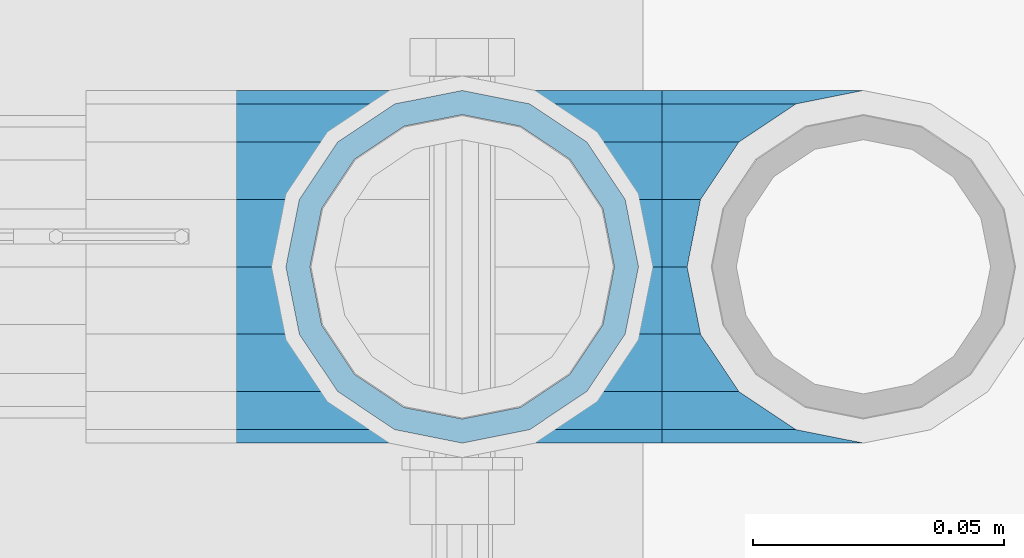
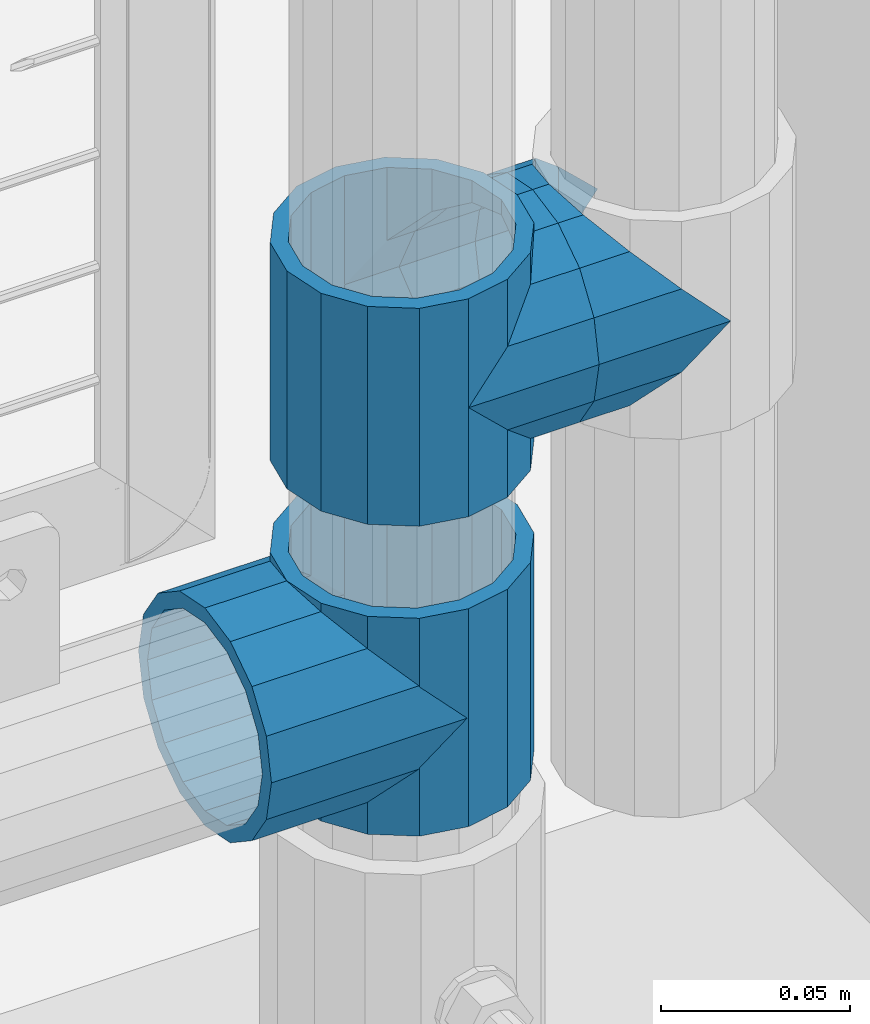
# One storey, part 139 of 208: 5 beams.
"""IFC2X3 building model written with IfcOpenShell, lengths in millimetres."""

import ifcopenshell
import ifcopenshell.guid

model = None  # the IFC model being written
_history = None  # IfcOwnerHistory: only IFC2X3 demands one
_inside = {}  # id of a spatial element -> (the spatial element, [elements in it])
_under = {}  # id of a project, library or spatial element -> (it, [spatial elements below it])
_declared = {}  # id of a project -> (the project, [libraries it declares])
_typed = {}  # id of a type object -> (the type object, [elements of that type])
_made_of = {}  # id of a material, layer set ... -> (it, [elements and type objects made of it])


def new_model(schema):
    """Start an empty IFC model of exactly this schema.

    Asked for "IFC4X3", IfcOpenShell would pick the latest addendum, in which some entities
    have other attributes; the version numbers below select the first issue.
    IFC2X3 requires an IfcOwnerHistory on every rooted entity: one is made here for all.
    """
    global model, _history
    if schema == "IFC4X3":
        model = ifcopenshell.file(schema_version=(4, 3, 0, 0))
    else:
        model = ifcopenshell.file(schema=schema)
    _inside.clear()
    _under.clear()
    _declared.clear()
    _typed.clear()
    _made_of.clear()
    _history = None
    if model.schema == "IFC2X3":
        org = make("IfcOrganization", Name="unknown")
        user = make(
            "IfcPersonAndOrganization",
            ThePerson=make("IfcPerson", FamilyName="unknown"),
            TheOrganization=org,
        )
        app = make(
            "IfcApplication",
            ApplicationDeveloper=org,
            Version="unknown",
            ApplicationFullName="unknown",
            ApplicationIdentifier="unknown",
        )
        _history = make(
            "IfcOwnerHistory",
            OwningUser=user,
            OwningApplication=app,
            ChangeAction="ADDED",
            CreationDate=0,
        )
    return model


def make(cls, **values):
    """One entity of the class cls with the attributes given. An attribute that is None is left unset."""
    return model.create_entity(
        cls, **{name: value for name, value in values.items() if value is not None}
    )


def rooted(cls, **values):
    """An entity with a GlobalId (a new one), such as an element, a storey or a relation."""
    return make(cls, GlobalId=ifcopenshell.guid.new(), OwnerHistory=_history, **values)


def si_unit(unit_type, name, prefix=None):
    """IfcSIUnit, for example si_unit("LENGTHUNIT", "METRE", prefix="MILLI")."""
    return make("IfcSIUnit", UnitType=unit_type, Prefix=prefix, Name=name)


def assignment(units):
    """IfcUnitAssignment: the units of a project."""
    return None if units is None else make("IfcUnitAssignment", Units=units)


def point(xyz):
    """IfcCartesianPoint."""
    return None if xyz is None else make("IfcCartesianPoint", Coordinates=xyz)


def direction(xyz):
    """IfcDirection."""
    return None if xyz is None else make("IfcDirection", DirectionRatios=xyz)


def frame(location, z_axis=None, x_axis=None):
    """IfcAxis2Placement3D, a coordinate frame: its origin and axes. An axis left out is left unset."""
    return make(
        "IfcAxis2Placement3D",
        Location=point(location),
        Axis=direction(z_axis),
        RefDirection=direction(x_axis),
    )


def origin_with_axes():
    """The frame at (0, 0, 0) with the z axis (0, 0, 1) and the x axis (1, 0, 0) written out."""
    return frame((0.0, 0.0, 0.0), z_axis=(0.0, 0.0, 1.0), x_axis=(1.0, 0.0, 0.0))


def place(relative_to, where):
    """IfcLocalPlacement: puts the frame where relative to a parent placement (None: the world)."""
    return make(
        "IfcLocalPlacement", PlacementRelTo=relative_to, RelativePlacement=where
    )


def context(
    kind, dimensions, precision=None, world=None, true_north=None, identifier=None
):
    """IfcGeometricRepresentationContext, for example the 3D "Model" context."""
    return make(
        "IfcGeometricRepresentationContext",
        ContextIdentifier=identifier,
        ContextType=kind,
        CoordinateSpaceDimension=dimensions,
        Precision=precision,
        WorldCoordinateSystem=world,
        TrueNorth=true_north,
    )


def subcontext(parent, identifier, kind, view, scale=None):
    """IfcGeometricRepresentationSubContext, for example "Body" below "Model"."""
    return make(
        "IfcGeometricRepresentationSubContext",
        ContextIdentifier=identifier,
        ContextType=kind,
        ParentContext=parent,
        TargetScale=scale,
        TargetView=view,
    )


def project(units=None, contexts=None):
    """IfcProject with its units and contexts."""
    return rooted(
        "IfcProject",
        Name="project",
        RepresentationContexts=contexts,
        UnitsInContext=assignment(units),
    )


def spatial(cls, under=None, at=None, **own):
    """A site, building, storey or space (cls), placed at a placement, below another one or the project."""
    s = rooted(cls, ObjectPlacement=at, **own)
    if under is not None:
        _under.setdefault(under.id(), (under, []))[1].append(s)
    return s


def faces_of(points, faces, orient=None, outer=None):
    """IfcFace entities. A face is a list of loops; a loop is a list of indices into points, from 0.

    orient and outer hold one flag for each loop. By default every Orientation is true, the
    first loop of a face is its IfcFaceOuterBound and the others are IfcFaceBound.
    """
    made = []
    for i, loops in enumerate(faces):
        bounds = []
        for j, loop in enumerate(loops):
            is_outer = j == 0 if outer is None else outer[i][j]
            bounds.append(
                make(
                    "IfcFaceOuterBound" if is_outer else "IfcFaceBound",
                    Bound=make("IfcPolyLoop", Polygon=[points[k] for k in loop]),
                    Orientation=True if orient is None else orient[i][j],
                )
            )
        made.append(make("IfcFace", Bounds=bounds))
    return made


def faceted_brep(points, faces, orient=None, outer=None, voids=None):
    """IfcFacetedBrep: a solid bounded by flat faces; with voids (closed shells), ...WithVoids."""
    shared = [point(p) for p in points]
    hull = make("IfcClosedShell", CfsFaces=faces_of(shared, faces, orient, outer))
    if voids is None:
        return make("IfcFacetedBrep", Outer=hull)
    return make(
        "IfcFacetedBrepWithVoids",
        Outer=hull,
        Voids=[
            make(cls, CfsFaces=faces_of(shared, fs, o, b)) for cls, fs, o, b in voids
        ],
    )


def shape(context_of_items, identifier, shape_type, items):
    """IfcShapeRepresentation: the items that make up one representation, for example the "Body"."""
    return make(
        "IfcShapeRepresentation",
        ContextOfItems=context_of_items,
        RepresentationIdentifier=identifier,
        RepresentationType=shape_type,
        Items=items,
    )


def material(Name=None, Category=None):
    """IfcMaterial."""
    return make("IfcMaterial", Name=Name, Category=Category)


def made_of(thing, what):
    """Note that an element or type object is made of a material, layer set ...; save() writes the relation."""
    if what is not None:
        _made_of.setdefault(what.id(), (what, []))[1].append(thing)
    return thing


def type_object(cls, material=None, **own):
    """A type object (cls), such as IfcWallType, which elements share."""
    return made_of(rooted(cls, **own), material)


def element(
    cls,
    number,
    at=None,
    inside=None,
    cuts=None,
    type_object=None,
    material=None,
    context=None,
    identifier="Body",
    shape_type=None,
    held_by="IfcProductDefinitionShape",
    body=None,
    shapes=None,
    **own,
):
    """One element of the class cls, such as IfcWall. Its Tag is "e" and its number.

    at: its placement. inside: the storey or other place that contains it. cuts: it is an
    opening in that element (IfcRelVoidsElement). A single representation is given by context,
    identifier, shape_type and body (its items); several are given by shapes. held_by: the class
    of the entity that holds the representations. save() writes the other relations.
    """
    e = rooted(cls, Tag="e%d" % number, ObjectPlacement=at, **own)
    if body is not None:
        shapes = [shape(context, identifier, shape_type, body)]
    if shapes is not None:
        e.Representation = make(held_by, Representations=shapes)
    if inside is not None:
        _inside.setdefault(inside.id(), (inside, []))[1].append(e)
    if cuts is not None:
        rooted(
            "IfcRelVoidsElement", RelatingBuildingElement=cuts, RelatedOpeningElement=e
        )
    if type_object is not None:
        _typed.setdefault(type_object.id(), (type_object, []))[1].append(e)
    return made_of(e, material)


def aggregate(whole, parts):
    """IfcRelAggregates: a whole, such as a stair, and the parts it consists of."""
    return rooted("IfcRelAggregates", RelatingObject=whole, RelatedObjects=parts)


def save(model, path):
    """Write the relations noted so far, then the file.

    IfcRelAggregates (storeys below a building ...), IfcRelContainedInSpatialStructure (elements
    in a storey), IfcRelDefinesByType, IfcRelAssociatesMaterial and IfcRelDeclares: one each for
    every whole, place, type object, material and project.
    """
    for whole, parts in _under.values():
        aggregate(whole, parts)
    for where, things in _inside.values():
        rooted(
            "IfcRelContainedInSpatialStructure",
            RelatedElements=things,
            RelatingStructure=where,
        )
    for kind, things in _typed.values():
        rooted("IfcRelDefinesByType", RelatedObjects=things, RelatingType=kind)
    for what, things in _made_of.values():
        rooted("IfcRelAssociatesMaterial", RelatedObjects=things, RelatingMaterial=what)
    for by, libraries in _declared.values():
        rooted("IfcRelDeclares", RelatingContext=by, RelatedDefinitions=libraries)
    model.write(path)


model = new_model("IFC2X3")

# Units and contexts
model_context = context("Model", 3, precision=1e-05, world=origin_with_axes())
body_context = subcontext(model_context, "Body", "Model", "MODEL_VIEW")
ifc_project = project(units=[si_unit("LENGTHUNIT", "METRE", prefix="MILLI"), si_unit("AREAUNIT", "SQUARE_METRE"), si_unit("VOLUMEUNIT", "CUBIC_METRE"), si_unit("MASSUNIT", "GRAM", prefix="KILO"), si_unit("TIMEUNIT", "SECOND"), si_unit("PLANEANGLEUNIT", "RADIAN"), si_unit("SOLIDANGLEUNIT", "STERADIAN"), si_unit("THERMODYNAMICTEMPERATUREUNIT", "DEGREE_CELSIUS"), si_unit("LUMINOUSINTENSITYUNIT", "LUMEN")], contexts=[model_context])

# Site, building, storey
site_placement = place(None, origin_with_axes())
site = spatial("IfcSite", under=ifc_project, at=site_placement, CompositionType="ELEMENT")
building_placement = place(site_placement, origin_with_axes())
building = spatial("IfcBuilding", under=site, at=building_placement, Name="Standard", CompositionType="ELEMENT")
storey_placement = place(building_placement, origin_with_axes())
storey = spatial("IfcBuildingStorey", under=building, at=storey_placement, Name="Undefined", CompositionType="ELEMENT", Elevation=0.0)

# Beams
ifc_material = material(Name="Misc_Undefined")
beam_type = type_object("IfcBeamType", PredefinedType="NOTDEFINED")
beam_1_placement = place(storey_placement, frame((-26229.0, 4664.5, 298.670000000001), z_axis=(0.0, 1.0, 0.0), x_axis=(-1.0, 0.0, 0.0)))
element("IfcBeam", 1, at=beam_1_placement, inside=storey, type_object=beam_type, material=ifc_material, context=body_context, shape_type="Brep", body=[
    faceted_brep([(13.4513226476338, -13.4513226476329, -32.4743655677721), (13.4513226476338, 13.4513226476329, -32.4743655677721), (0.0, 0.0, -35.1499999999996), (24.8548033587067, -24.8548033587072, 24.8548033587067), (24.8548033587067, -16.3810424080039, 24.8548033587067), (27.1226768591005, -21.4606908090117, 21.4606908090118), (32.4743655677739, -26.8123795176755, 13.4513226476329), (32.4743655677739, -32.4743655677717, 13.4513226476329), (32.8397438117172, -28.0397438117175, 11.6144421722802), (35.1500000000015, -30.35, 0.0), (35.1500000000015, -35.1499999999996, 0.0), (32.8397438117172, -28.0397438117175, -11.6144421722802), (32.4743655677739, -26.8123795176766, -13.4513226476329), (32.4743655677739, -32.4743655677717, -13.4513226476329), (27.1226768591077, -21.4606908090117, -21.4606908090118), (24.8548033587067, -16.3810424080039, -24.8548033587067), (24.8548033587067, -24.8548033587072, -24.8548033587067), (20.0882031229849, -11.6144421722805, -28.0397438117179), (16.6306603983685, 0.0, -30.3500000000004), (20.0882031229849, 11.6144421722805, -28.0397438117179), (24.8548033587067, 16.3810424080023, -24.8548033587067), (24.8548033587067, 24.8548033587072, -24.8548033587067), (32.4743655677739, 26.8123795176755, -13.4513226476329), (32.4743655677739, 32.4743655677717, -13.4513226476329), (27.1226768591077, 21.4606908090117, -21.4606908090118), (35.1500000000015, 30.35, 0.0), (35.1500000000015, 35.15, 0.0), (32.8397438117172, 28.0397438117175, -11.6144421722802), (32.8397438117172, 28.0397438117175, 11.6144421722802), (32.4743655677739, 26.812379517676, 13.4513226476329), (32.4743655677739, 32.4743655677717, 13.4513226476329), (27.1226768591005, 21.4606908090117, 21.4606908090118), (24.8548033587067, 16.3810424080032, 24.8548033587067), (24.8548033587067, 24.8548033587072, 24.8548033587067), (0.0, 0.0, 35.1499999999996), (13.4513226476338, 13.4513226476329, 32.4743655677721), (13.4513226476338, -13.4513226476329, 32.4743655677721), (20.0882031229921, 11.6144421722805, 28.0397438117179), (16.6306603983685, 0.0, 30.3500000000004), (20.0882031229921, -11.6144421722805, 28.0397438117179), (60.1500000000015, -35.15, 0.0), (60.1500000000015, -32.4743655677717, 13.4513226476329), (60.1500000000015, -24.8548033587072, 24.8548033587067), (60.1500000000015, -13.4513226476329, 32.4743655677721), (60.1500000000015, 0.0, 35.1499999999996), (60.1500000000015, -24.8548033587072, -24.8548033587067), (60.1500000000015, -32.4743655677717, -13.4513226476329), (60.1500000000015, -13.4513226476329, -32.4743655677721), (60.1500000000015, 0.0, -35.1499999999996), (60.1500000000015, 13.4513226476329, -32.4743655677721), (60.1500000000015, 24.8548033587072, -24.8548033587067), (60.1500000000015, 32.4743655677717, -13.4513226476329), (60.1500000000015, 35.15, 0.0), (60.1500000000015, 32.4743655677717, 13.4513226476329), (60.1500000000015, 24.8548033587072, 24.8548033587067), (60.1500000000015, 13.4513226476329, 32.4743655677721), (60.1500000000015, -21.4606908090117, 21.4606908090118), (60.1500000000015, -11.6144421722805, 28.0397438117179), (60.1500000000015, 0.0, 30.3500000000004), (60.1500000000015, 11.6144421722805, 28.0397438117179), (60.1500000000015, 21.4606908090117, 21.4606908090118), (60.1500000000015, 28.0397438117175, 11.6144421722802), (60.1500000000015, 30.35, 0.0), (60.1500000000015, 28.0397438117175, -11.6144421722802), (60.1500000000015, 21.4606908090117, -21.4606908090118), (60.1500000000015, 11.6144421722805, -28.0397438117179), (60.1500000000015, 0.0, -30.3500000000004), (60.1500000000015, -11.6144421722805, -28.0397438117179), (60.1500000000015, -21.4606908090117, -21.4606908090118), (60.1500000000015, -28.0397438117175, -11.6144421722802), (60.1500000000015, -30.35, 0.0), (60.1500000000015, -28.0397438117175, 11.6144421722802)], [[[0, 1, 2]], [[3, 4, 5, 6, 7]], [[7, 6, 8, 9, 10]], [[10, 9, 11, 12, 13]], [[13, 12, 14, 15, 16]], [[16, 15, 17, 18, 19, 20, 21, 1, 0]], [[22, 23, 21, 20, 24]], [[25, 26, 23, 22, 27]], [[28, 29, 30, 26, 25]], [[31, 32, 33, 30, 29]], [[34, 35, 36]], [[36, 35, 33, 32, 37, 38, 39, 4, 3]], [[40, 41, 7, 10]], [[41, 42, 3, 7]], [[42, 43, 36, 3]], [[43, 44, 34, 36]], [[45, 46, 13, 16]], [[47, 45, 16, 0]], [[48, 47, 0, 2]], [[49, 48, 2, 1]], [[50, 49, 1, 21]], [[51, 50, 21, 23]], [[52, 51, 23, 26]], [[53, 52, 26, 30]], [[54, 53, 30, 33]], [[55, 54, 33, 35]], [[44, 55, 35, 34]], [[46, 40, 10, 13]], [[45, 47, 48, 49, 50, 51, 52, 53, 54, 55, 44, 43, 42, 41, 40, 46], [56, 57, 58, 59, 60, 61, 62, 63, 64, 65, 66, 67, 68, 69, 70, 71]], [[59, 58, 38, 37]], [[60, 59, 37, 32, 31]], [[61, 60, 31, 29, 28]], [[62, 61, 28, 25]], [[63, 62, 25, 27]], [[24, 64, 63, 27, 22]], [[19, 65, 64, 24, 20]], [[66, 65, 19, 18]], [[67, 66, 18, 17]], [[68, 67, 17, 15, 14]], [[69, 68, 14, 12, 11]], [[70, 69, 11, 9]], [[71, 70, 9, 8]], [[5, 56, 71, 8, 6]], [[39, 57, 56, 5, 4]], [[58, 57, 39, 38]]]),
])
beam_2_placement = place(storey_placement, frame((-26229.0, 4664.5, 333.820000000001), z_axis=(1.0, 0.0, 0.0), x_axis=(0.0, 0.0, -1.0)))
element("IfcBeam", 2, at=beam_2_placement, inside=storey, type_object=beam_type, material=ifc_material, context=body_context, shape_type="Brep", body=[
    faceted_brep([(56.6106908090114, 21.4606908090118, -27.1226768591077), (56.6106908090114, 21.4606908090118, -21.4606908090136), (46.7644421722801, 28.0397438117179, -11.6144421722784), (46.7644421722801, 28.0397438117179, -20.0882031229921), (51.531042408003, 24.8548033587067, -24.8548033587067), (63.1897438117172, 11.6144421722802, -32.8397438117245), (63.1897438117172, 11.6144421722802, -28.0397438117143), (61.962379517676, 13.4513226476329, -32.4743655677739), (65.4999999999997, 0.0, -35.1500000000015), (65.4999999999997, 0.0, -30.3499999999985), (63.1897438117172, -11.6144421722802, -32.8397438117245), (63.1897438117172, -11.6144421722802, -28.0397438117143), (61.962379517675, -13.4513226476329, -32.4743655677739), (56.6106908090114, -21.4606908090118, -27.1226768591005), (56.6106908090114, -21.4606908090118, -21.4606908090136), (51.531042408003, -24.8548033587067, -24.8548033587067), (46.7644421722801, -28.0397438117179, -20.0882031229921), (46.7644421722801, -28.0397438117179, -11.6144421722784), (35.1499999999996, -30.3500000000004, -16.6306603983685), (35.1500000000015, -30.35, 0.0), (23.5355578277191, -28.0397438117179, -20.0882031229921), (23.5355578277191, -28.0397438117179, -11.6144421722784), (13.6893091909879, -21.4606908090118, -27.1226768591005), (13.6893091909879, -21.4606908090118, -21.4606908090136), (18.7689575919962, -24.8548033587067, -24.8548033587067), (7.11025618828205, -11.6144421722802, -32.8397438117245), (7.11025618828205, -11.6144421722802, -28.0397438117143), (8.33762048232325, -13.4513226476329, -32.4743655677739), (4.79999999999961, 0.0, -35.1500000000015), (4.79999999999961, 0.0, -30.3499999999985), (7.11025618828211, 11.6144421722802, -32.8397438117245), (7.11025618828211, 11.6144421722802, -28.0397438117143), (8.33762048232325, 13.4513226476329, -32.4743655677739), (13.6893091909879, 21.4606908090118, -27.1226768591077), (13.6893091909879, 21.4606908090118, -21.4606908090136), (18.7689575919962, 24.8548033587067, -24.8548033587067), (23.5355578277192, 28.0397438117179, -20.0882031229921), (23.5355578277192, 28.0397438117179, -11.6144421722784), (35.1499999999996, 30.3500000000004, -16.6306603983685), (35.1500000000015, 30.35, 0.0), (0.0, 32.4743655677721, -13.4513226476338), (0.0, 35.1499999999996, 0.0), (70.2999999999993, 35.1499999999996, 0.0), (70.2999999999993, 32.4743655677721, -13.4513226476338), (0.0, 32.4743655677721, 13.4513226476338), (70.2999999999993, 32.4743655677721, 13.4513226476338), (0.0, 24.8548033587067, 24.8548033587067), (70.2999999999993, 24.8548033587067, 24.8548033587067), (0.0, 13.4513226476329, 32.4743655677739), (70.2999999999993, 13.4513226476329, 32.4743655677739), (0.0, 0.0, 35.1499999999996), (70.2999999999993, 0.0, 35.1500000000015), (0.0, -13.4513226476329, 32.4743655677739), (70.2999999999993, -13.4513226476329, 32.4743655677739), (0.0, -24.8548033587067, 24.8548033587067), (70.2999999999993, -24.8548033587067, 24.8548033587067), (0.0, -32.4743655677721, 13.4513226476338), (70.2999999999993, -32.4743655677721, 13.4513226476338), (0.0, -35.1499999999996, 0.0), (70.2999999999993, -35.1499999999996, 0.0), (70.2999999999993, -30.3500000000004, 0.0), (70.2999999999993, -28.0397438117179, -11.6144421722784), (70.2999999999993, -21.4606908090118, -21.4606908090136), (70.2999999999993, -11.6144421722802, -28.0397438117143), (70.2999999999993, 0.0, -30.3499999999985), (70.2999999999993, 11.6144421722802, -28.0397438117143), (70.2999999999993, 21.4606908090118, -21.4606908090136), (70.2999999999993, 28.0397438117179, -11.6144421722784), (0.0, -28.0397438117179, -11.6144421722784), (0.0, -30.3500000000004, 0.0), (0.0, -21.4606908090118, -21.4606908090136), (0.0, -11.6144421722802, -28.0397438117143), (0.0, 0.0, -30.3499999999985), (0.0, 11.6144421722802, -28.0397438117143), (0.0, 21.4606908090118, -21.4606908090136), (0.0, 28.0397438117179, -11.6144421722784), (0.0, 30.3500000000004, 0.0), (70.2999999999993, 30.3500000000004, 0.0), (0.0, 28.0397438117179, 11.6144421722784), (70.2999999999993, 28.0397438117179, 11.6144421722784), (0.0, 21.4606908090118, 21.4606908090136), (70.2999999999993, 21.4606908090118, 21.4606908090136), (0.0, 11.6144421722802, 28.0397438117143), (70.2999999999993, 11.6144421722802, 28.0397438117143), (0.0, 0.0, 30.3499999999985), (70.2999999999993, 0.0, 30.3499999999985), (0.0, -11.6144421722802, 28.0397438117143), (70.2999999999993, -11.6144421722802, 28.0397438117143), (0.0, -21.4606908090118, 21.4606908090136), (70.2999999999993, -21.4606908090118, 21.4606908090136), (0.0, -28.0397438117179, 11.6144421722784), (70.2999999999993, -28.0397438117179, 11.6144421722784), (70.2999999999993, -24.8548033587067, -24.8548033587067), (70.2999999999993, -13.4513226476329, -32.4743655677739), (70.2999999999993, 0.0, -35.1500000000015), (70.2999999999993, 13.4513226476329, -32.4743655677739), (70.2999999999993, 24.8548033587067, -24.8548033587067), (70.2999999999993, -32.4743655677721, -13.4513226476338), (0.0, -32.4743655677721, -13.4513226476338), (0.0, 24.8548033587067, -24.8548033587067), (0.0, 13.4513226476329, -32.4743655677739), (0.0, 0.0, -35.1499999999996), (0.0, -13.4513226476329, -32.4743655677739), (0.0, -24.8548033587067, -24.8548033587067)], [[[0, 1, 2, 3, 4]], [[5, 6, 1, 0, 7]], [[8, 9, 6, 5]], [[10, 11, 9, 8]], [[12, 13, 14, 11, 10]], [[15, 16, 17, 14, 13]], [[18, 19, 17, 16]], [[20, 21, 19, 18]], [[22, 23, 21, 20, 24]], [[25, 26, 23, 22, 27]], [[28, 29, 26, 25]], [[30, 31, 29, 28]], [[32, 33, 34, 31, 30]], [[35, 36, 37, 34, 33]], [[38, 39, 37, 36]], [[3, 2, 39, 38]], [[40, 41, 42, 43]], [[41, 44, 45, 42]], [[44, 46, 47, 45]], [[46, 48, 49, 47]], [[48, 50, 51, 49]], [[50, 52, 53, 51]], [[52, 54, 55, 53]], [[54, 56, 57, 55]], [[56, 58, 59, 57]], [[60, 61, 17, 19]], [[61, 62, 14, 17]], [[62, 63, 11, 14]], [[63, 64, 9, 11]], [[64, 65, 6, 9]], [[65, 66, 1, 6]], [[66, 67, 2, 1]], [[68, 69, 19, 21]], [[70, 68, 21, 23]], [[71, 70, 23, 26]], [[72, 71, 26, 29]], [[73, 72, 29, 31]], [[74, 73, 31, 34]], [[75, 74, 34, 37]], [[76, 75, 37, 39]], [[67, 77, 39, 2]], [[78, 76, 39, 77, 79]], [[80, 78, 79, 81]], [[82, 80, 81, 83]], [[84, 82, 83, 85]], [[86, 84, 85, 87]], [[88, 86, 87, 89]], [[90, 88, 89, 91]], [[19, 69, 90, 91, 60]], [[92, 93, 94, 95, 96, 43, 42, 45, 47, 49, 51, 53, 55, 57, 59, 97], [89, 87, 85, 83, 81, 79, 77, 67, 66, 65, 64, 63, 62, 61, 60, 91]], [[58, 98, 97, 59]], [[56, 54, 52, 50, 48, 46, 44, 41, 40, 99, 100, 101, 102, 103, 98, 58], [68, 70, 71, 72, 73, 74, 75, 76, 78, 80, 82, 84, 86, 88, 90, 69]], [[100, 99, 35, 33, 32]], [[101, 100, 32, 30, 28]], [[27, 102, 101, 28, 25]], [[24, 103, 102, 27, 22]], [[92, 97, 98, 103, 24, 20, 18, 16, 15]], [[93, 92, 15, 13, 12]], [[94, 93, 12, 10, 8]], [[7, 95, 94, 8, 5]], [[4, 96, 95, 7, 0]], [[38, 36, 35, 99, 40, 43, 96, 4, 3]]]),
])
beam_3_placement = place(storey_placement, frame((-26229.0, 4664.5, 398.670000000001), z_axis=(0.0, -1.0, 0.0), x_axis=(1.0, 0.0, 0.0)))
element("IfcBeam", 3, at=beam_3_placement, inside=storey, type_object=beam_type, material=ifc_material, context=body_context, shape_type="Brep", body=[
    faceted_brep([(13.4513226476338, -13.4513226476329, -32.4743655677721), (13.4513226476338, 13.4513226476329, -32.4743655677721), (0.0, 0.0, -35.1499999999996), (27.1226768591005, 21.4606908090117, 21.4606908090118), (24.8548033587067, 16.3810424080032, 24.8548033587067), (24.8548033587067, 24.8548033587072, 24.8548033587067), (32.4743655677739, 32.4743655677717, 13.4513226476329), (32.4743655677739, 26.812379517676, 13.4513226476329), (0.0, 0.0, 35.1499999999996), (13.4513226476338, 13.4513226476329, 32.4743655677721), (13.4513226476338, -13.4513226476329, 32.4743655677721), (20.0882031229921, 11.6144421722805, 28.0397438117179), (16.6306603983685, 0.0, 30.3500000000004), (20.0882031229921, -11.6144421722805, 28.0397438117179), (24.8548033587067, -16.3810424080039, 24.8548033587067), (24.8548033587067, -24.8548033587072, 24.8548033587067), (27.1226768591005, -21.4606908090117, 21.4606908090118), (32.4743655677739, -26.8123795176755, 13.4513226476329), (32.4743655677739, -32.4743655677717, 13.4513226476329), (32.8397438117172, -28.0397438117175, 11.6144421722802), (35.1500000000015, -30.35, 0.0), (35.1500000000015, -35.1499999999996, 0.0), (32.8397438117172, -28.0397438117175, -11.6144421722802), (32.4743655677739, -26.8123795176766, -13.4513226476329), (32.4743655677739, -32.4743655677717, -13.4513226476329), (27.1226768591077, -21.4606908090117, -21.4606908090118), (24.8548033587067, -16.3810424080039, -24.8548033587067), (24.8548033587067, -24.8548033587072, -24.8548033587067), (20.0882031229849, -11.6144421722805, -28.0397438117179), (16.6306603983685, 0.0, -30.3500000000004), (20.0882031229849, 11.6144421722805, -28.0397438117179), (24.8548033587067, 16.3810424080023, -24.8548033587067), (24.8548033587067, 24.8548033587072, -24.8548033587067), (32.4743655677739, 26.8123795176755, -13.4513226476329), (32.4743655677739, 32.4743655677717, -13.4513226476329), (27.1226768591077, 21.4606908090117, -21.4606908090118), (35.1500000000015, 30.35, 0.0), (35.1500000000015, 35.15, 0.0), (32.8397438117172, 28.0397438117175, -11.6144421722802), (32.8397438117172, 28.0397438117175, 11.6144421722802), (40.1500000000015, -35.15, 0.0), (40.1500000000015, -32.4743655677717, 13.4513226476329), (40.1500000000015, -24.8548033587072, 24.8548033587067), (40.1500000000015, -13.4513226476329, 32.4743655677721), (40.1500000000015, 0.0, 35.1499999999996), (40.1500000000015, 13.4513226476329, 32.4743655677721), (40.1500000000015, 24.8548033587072, 24.8548033587067), (40.1500000000015, 32.4743655677717, 13.4513226476329), (40.1500000000015, 35.15, 0.0), (40.1500000000015, -24.8548033587072, -24.8548033587067), (40.1500000000015, -32.4743655677717, -13.4513226476329), (40.1500000000015, -13.4513226476329, -32.4743655677721), (40.1500000000015, 0.0, -35.1499999999996), (40.1500000000015, 13.4513226476329, -32.4743655677721), (40.1500000000015, 24.8548033587072, -24.8548033587067), (40.1500000000015, 32.4743655677717, -13.4513226476329), (40.1500000000015, -21.4606908090117, 21.4606908090118), (40.1500000000015, -11.6144421722805, 28.0397438117179), (40.1500000000015, 0.0, 30.3500000000004), (40.1500000000015, 11.6144421722805, 28.0397438117179), (40.1500000000015, 21.4606908090117, 21.4606908090118), (40.1500000000015, 28.0397438117175, 11.6144421722802), (40.1500000000015, 30.35, 0.0), (40.1500000000015, 28.0397438117175, -11.6144421722802), (40.1500000000015, 21.4606908090117, -21.4606908090118), (40.1500000000015, 11.6144421722805, -28.0397438117179), (40.1500000000015, 0.0, -30.3500000000004), (40.1500000000015, -11.6144421722805, -28.0397438117179), (40.1500000000015, -21.4606908090117, -21.4606908090118), (40.1500000000015, -28.0397438117175, -11.6144421722802), (40.1500000000015, -30.35, 0.0), (40.1500000000015, -28.0397438117175, 11.6144421722802)], [[[0, 1, 2]], [[3, 4, 5, 6, 7]], [[8, 9, 10]], [[10, 9, 5, 4, 11, 12, 13, 14, 15]], [[15, 14, 16, 17, 18]], [[18, 17, 19, 20, 21]], [[21, 20, 22, 23, 24]], [[24, 23, 25, 26, 27]], [[27, 26, 28, 29, 30, 31, 32, 1, 0]], [[33, 34, 32, 31, 35]], [[36, 37, 34, 33, 38]], [[39, 7, 6, 37, 36]], [[40, 41, 18, 21]], [[41, 42, 15, 18]], [[42, 43, 10, 15]], [[43, 44, 8, 10]], [[44, 45, 9, 8]], [[45, 46, 5, 9]], [[46, 47, 6, 5]], [[47, 48, 37, 6]], [[49, 50, 24, 27]], [[51, 49, 27, 0]], [[52, 51, 0, 2]], [[53, 52, 2, 1]], [[54, 53, 1, 32]], [[55, 54, 32, 34]], [[48, 55, 34, 37]], [[50, 40, 21, 24]], [[49, 51, 52, 53, 54, 55, 48, 47, 46, 45, 44, 43, 42, 41, 40, 50], [56, 57, 58, 59, 60, 61, 62, 63, 64, 65, 66, 67, 68, 69, 70, 71]], [[63, 62, 36, 38]], [[35, 64, 63, 38, 33]], [[30, 65, 64, 35, 31]], [[66, 65, 30, 29]], [[67, 66, 29, 28]], [[68, 67, 28, 26, 25]], [[69, 68, 25, 23, 22]], [[70, 69, 22, 20]], [[71, 70, 20, 19]], [[16, 56, 71, 19, 17]], [[13, 57, 56, 16, 14]], [[58, 57, 13, 12]], [[59, 58, 12, 11]], [[60, 59, 11, 4, 3]], [[61, 60, 3, 7, 39]], [[62, 61, 39, 36]]]),
])
beam_4_placement = place(storey_placement, frame((-26149.0, 4664.5, 398.670000000001), z_axis=(0.0, 1.0, 0.0), x_axis=(-1.0, 0.0, 0.0)))
element("IfcBeam", 4, at=beam_4_placement, inside=storey, type_object=beam_type, material=ifc_material, context=body_context, shape_type="Brep", body=[
    faceted_brep([(13.4513226476338, -13.4513226476329, -32.4743655677721), (13.4513226476338, 13.4513226476329, -32.4743655677721), (0.0, 0.0, -35.1499999999996), (24.8548033587067, -24.8548033587072, 24.8548033587067), (24.8548033587067, -16.3810424080039, 24.8548033587067), (27.1226768591005, -21.4606908090117, 21.4606908090118), (32.4743655677739, -26.8123795176755, 13.4513226476329), (32.4743655677739, -32.4743655677717, 13.4513226476329), (32.8397438117172, -28.0397438117175, 11.6144421722802), (35.1500000000015, -30.35, 0.0), (35.1500000000015, -35.1499999999996, 0.0), (32.8397438117172, -28.0397438117175, -11.6144421722802), (32.4743655677739, -26.8123795176766, -13.4513226476329), (32.4743655677739, -32.4743655677717, -13.4513226476329), (27.1226768591077, -21.4606908090117, -21.4606908090118), (24.8548033587067, -16.3810424080039, -24.8548033587067), (24.8548033587067, -24.8548033587072, -24.8548033587067), (20.0882031229849, -11.6144421722805, -28.0397438117179), (16.6306603983685, 0.0, -30.3500000000004), (20.0882031229849, 11.6144421722805, -28.0397438117179), (24.8548033587067, 16.3810424080023, -24.8548033587067), (24.8548033587067, 24.8548033587072, -24.8548033587067), (32.4743655677739, 26.8123795176755, -13.4513226476329), (32.4743655677739, 32.4743655677717, -13.4513226476329), (27.1226768591077, 21.4606908090117, -21.4606908090118), (35.1500000000015, 30.35, 0.0), (35.1500000000015, 35.15, 0.0), (32.8397438117172, 28.0397438117175, -11.6144421722802), (32.8397438117172, 28.0397438117175, 11.6144421722802), (32.4743655677739, 26.812379517676, 13.4513226476329), (32.4743655677739, 32.4743655677717, 13.4513226476329), (27.1226768591005, 21.4606908090117, 21.4606908090118), (24.8548033587067, 16.3810424080032, 24.8548033587067), (24.8548033587067, 24.8548033587072, 24.8548033587067), (0.0, 0.0, 35.1499999999996), (13.4513226476338, 13.4513226476329, 32.4743655677721), (13.4513226476338, -13.4513226476329, 32.4743655677721), (20.0882031229921, 11.6144421722805, 28.0397438117179), (16.6306603983685, 0.0, 30.3500000000004), (20.0882031229921, -11.6144421722805, 28.0397438117179), (40.1500000000015, -35.15, 0.0), (40.1500000000015, -32.4743655677717, 13.4513226476329), (40.1500000000015, -24.8548033587072, 24.8548033587067), (40.1500000000015, -13.4513226476329, 32.4743655677721), (40.1500000000015, 0.0, 35.1499999999996), (40.1500000000015, -24.8548033587072, -24.8548033587067), (40.1500000000015, -32.4743655677717, -13.4513226476329), (40.1500000000015, -13.4513226476329, -32.4743655677721), (40.1500000000015, 0.0, -35.1499999999996), (40.1500000000015, 13.4513226476329, -32.4743655677721), (40.1500000000015, 24.8548033587072, -24.8548033587067), (40.1500000000015, 32.4743655677717, -13.4513226476329), (40.1500000000015, 35.15, 0.0), (40.1500000000015, 32.4743655677717, 13.4513226476329), (40.1500000000015, 24.8548033587072, 24.8548033587067), (40.1500000000015, 13.4513226476329, 32.4743655677721), (40.1500000000015, -21.4606908090117, 21.4606908090118), (40.1500000000015, -11.6144421722805, 28.0397438117179), (40.1500000000015, 0.0, 30.3500000000004), (40.1500000000015, 11.6144421722805, 28.0397438117179), (40.1500000000015, 21.4606908090117, 21.4606908090118), (40.1500000000015, 28.0397438117175, 11.6144421722802), (40.1500000000015, 30.35, 0.0), (40.1500000000015, 28.0397438117175, -11.6144421722802), (40.1500000000015, 21.4606908090117, -21.4606908090118), (40.1500000000015, 11.6144421722805, -28.0397438117179), (40.1500000000015, 0.0, -30.3500000000004), (40.1500000000015, -11.6144421722805, -28.0397438117179), (40.1500000000015, -21.4606908090117, -21.4606908090118), (40.1500000000015, -28.0397438117175, -11.6144421722802), (40.1500000000015, -30.35, 0.0), (40.1500000000015, -28.0397438117175, 11.6144421722802)], [[[0, 1, 2]], [[3, 4, 5, 6, 7]], [[7, 6, 8, 9, 10]], [[10, 9, 11, 12, 13]], [[13, 12, 14, 15, 16]], [[16, 15, 17, 18, 19, 20, 21, 1, 0]], [[22, 23, 21, 20, 24]], [[25, 26, 23, 22, 27]], [[28, 29, 30, 26, 25]], [[31, 32, 33, 30, 29]], [[34, 35, 36]], [[36, 35, 33, 32, 37, 38, 39, 4, 3]], [[40, 41, 7, 10]], [[41, 42, 3, 7]], [[42, 43, 36, 3]], [[43, 44, 34, 36]], [[45, 46, 13, 16]], [[47, 45, 16, 0]], [[48, 47, 0, 2]], [[49, 48, 2, 1]], [[50, 49, 1, 21]], [[51, 50, 21, 23]], [[52, 51, 23, 26]], [[53, 52, 26, 30]], [[54, 53, 30, 33]], [[55, 54, 33, 35]], [[44, 55, 35, 34]], [[46, 40, 10, 13]], [[45, 47, 48, 49, 50, 51, 52, 53, 54, 55, 44, 43, 42, 41, 40, 46], [56, 57, 58, 59, 60, 61, 62, 63, 64, 65, 66, 67, 68, 69, 70, 71]], [[59, 58, 38, 37]], [[60, 59, 37, 32, 31]], [[61, 60, 31, 29, 28]], [[62, 61, 28, 25]], [[63, 62, 25, 27]], [[24, 64, 63, 27, 22]], [[19, 65, 64, 24, 20]], [[66, 65, 19, 18]], [[67, 66, 18, 17]], [[68, 67, 17, 15, 14]], [[69, 68, 14, 12, 11]], [[70, 69, 11, 9]], [[71, 70, 9, 8]], [[5, 56, 71, 8, 6]], [[39, 57, 56, 5, 4]], [[58, 57, 39, 38]]]),
])
beam_5_placement = place(storey_placement, frame((-26229.0, 4664.5, 433.82), z_axis=(-1.0, 0.0, 0.0), x_axis=(0.0, 0.0, -1.0)))
element("IfcBeam", 5, at=beam_5_placement, inside=storey, type_object=beam_type, material=ifc_material, context=body_context, shape_type="Brep", body=[
    faceted_brep([(7.11025618828205, -11.6144421722802, -32.8397438117245), (7.11025618828205, -11.6144421722802, -28.0397438117143), (13.6893091909879, -21.4606908090118, -21.4606908090136), (13.6893091909879, -21.4606908090118, -27.1226768591005), (8.33762048232325, -13.4513226476329, -32.4743655677739), (23.5355578277191, -28.0397438117179, -11.6144421722784), (23.5355578277191, -28.0397438117179, -20.0882031229921), (18.7689575919962, -24.8548033587067, -24.8548033587067), (35.1500000000015, -30.35, 0.0), (35.1499999999996, -30.3500000000004, -16.6306603983685), (46.7644421722801, -28.0397438117179, -11.6144421722784), (46.7644421722801, -28.0397438117179, -20.0882031229921), (51.531042408003, -24.8548033587067, -24.8548033587067), (56.6106908090114, -21.4606908090118, -21.4606908090136), (56.6106908090114, -21.4606908090118, -27.1226768591005), (61.962379517675, -13.4513226476329, -32.4743655677739), (63.1897438117172, -11.6144421722802, -28.0397438117143), (63.1897438117172, -11.6144421722802, -32.8397438117245), (65.4999999999997, 0.0, -30.3499999999985), (65.4999999999997, 0.0, -35.1500000000015), (63.1897438117172, 11.6144421722802, -28.0397438117143), (63.1897438117172, 11.6144421722802, -32.8397438117245), (56.6106908090114, 21.4606908090118, -21.4606908090136), (56.6106908090114, 21.4606908090118, -27.1226768591077), (61.962379517676, 13.4513226476329, -32.4743655677739), (46.7644421722801, 28.0397438117179, -11.6144421722784), (46.7644421722801, 28.0397438117179, -20.0882031229921), (51.531042408003, 24.8548033587067, -24.8548033587067), (35.1500000000015, 30.35, 0.0), (35.1499999999996, 30.3500000000004, -16.6306603983685), (23.5355578277192, 28.0397438117179, -11.6144421722784), (23.5355578277192, 28.0397438117179, -20.0882031229921), (18.7689575919962, 24.8548033587067, -24.8548033587067), (13.6893091909879, 21.4606908090118, -21.4606908090136), (13.6893091909879, 21.4606908090118, -27.1226768591077), (8.33762048232325, 13.4513226476329, -32.4743655677739), (7.11025618828211, 11.6144421722802, -28.0397438117143), (7.11025618828211, 11.6144421722802, -32.8397438117245), (4.79999999999961, 0.0, -30.3499999999985), (4.79999999999961, 0.0, -35.1500000000015), (0.0, 21.4606908090118, 21.4606908090136), (0.0, 28.0397438117179, 11.6144421722784), (70.2999999999993, 28.0397438117179, 11.6144421722784), (70.2999999999993, 21.4606908090118, 21.4606908090136), (0.0, 11.6144421722802, 28.0397438117143), (70.2999999999993, 11.6144421722802, 28.0397438117143), (0.0, 0.0, 30.3499999999985), (70.2999999999993, 0.0, 30.3499999999985), (0.0, -11.6144421722802, 28.0397438117143), (70.2999999999993, -11.6144421722802, 28.0397438117143), (0.0, -21.4606908090118, 21.4606908090136), (70.2999999999993, -21.4606908090118, 21.4606908090136), (0.0, -28.0397438117179, 11.6144421722784), (70.2999999999993, -28.0397438117179, 11.6144421722784), (0.0, -24.8548033587067, -24.8548033587067), (0.0, -13.4513226476329, -32.4743655677739), (0.0, 0.0, -35.1499999999996), (0.0, -32.4743655677721, 13.4513226476338), (0.0, -35.1499999999996, 0.0), (70.2999999999993, -35.1499999999996, 0.0), (70.2999999999993, -32.4743655677721, 13.4513226476338), (0.0, -24.8548033587067, 24.8548033587067), (70.2999999999993, -24.8548033587067, 24.8548033587067), (0.0, -13.4513226476329, 32.4743655677739), (70.2999999999993, -13.4513226476329, 32.4743655677739), (0.0, 0.0, 35.1499999999996), (70.2999999999993, 0.0, 35.1500000000015), (0.0, 13.4513226476329, 32.4743655677739), (70.2999999999993, 13.4513226476329, 32.4743655677739), (0.0, 24.8548033587067, 24.8548033587067), (70.2999999999993, 24.8548033587067, 24.8548033587067), (0.0, 32.4743655677721, 13.4513226476338), (70.2999999999993, 32.4743655677721, 13.4513226476338), (0.0, 35.1499999999996, 0.0), (70.2999999999993, 35.1499999999996, 0.0), (0.0, 32.4743655677721, -13.4513226476338), (70.2999999999993, 32.4743655677721, -13.4513226476338), (70.2999999999993, -13.4513226476329, -32.4743655677739), (70.2999999999993, -24.8548033587067, -24.8548033587067), (70.2999999999993, 0.0, -35.1500000000015), (70.2999999999993, 13.4513226476329, -32.4743655677739), (70.2999999999993, 24.8548033587067, -24.8548033587067), (0.0, 24.8548033587067, -24.8548033587067), (0.0, 13.4513226476329, -32.4743655677739), (70.2999999999993, -32.4743655677721, -13.4513226476338), (0.0, -32.4743655677721, -13.4513226476338), (0.0, -28.0397438117179, -11.6144421722784), (0.0, -21.4606908090118, -21.4606908090136), (0.0, -11.6144421722802, -28.0397438117143), (0.0, 0.0, -30.3499999999985), (0.0, 11.6144421722802, -28.0397438117143), (0.0, 21.4606908090118, -21.4606908090136), (0.0, 28.0397438117179, -11.6144421722784), (0.0, 30.3500000000004, 0.0), (0.0, -30.3500000000004, 0.0), (70.2999999999993, 30.3500000000004, 0.0), (70.2999999999993, 28.0397438117179, -11.6144421722784), (70.2999999999993, 21.4606908090118, -21.4606908090136), (70.2999999999993, 11.6144421722802, -28.0397438117143), (70.2999999999993, 0.0, -30.3499999999985), (70.2999999999993, -11.6144421722802, -28.0397438117143), (70.2999999999993, -21.4606908090118, -21.4606908090136), (70.2999999999993, -28.0397438117179, -11.6144421722784), (70.2999999999993, -30.3500000000004, 0.0)], [[[0, 1, 2, 3, 4]], [[3, 2, 5, 6, 7]], [[6, 5, 8, 9]], [[9, 8, 10, 11]], [[12, 11, 10, 13, 14]], [[15, 14, 13, 16, 17]], [[17, 16, 18, 19]], [[19, 18, 20, 21]], [[21, 20, 22, 23, 24]], [[23, 22, 25, 26, 27]], [[26, 25, 28, 29]], [[29, 28, 30, 31]], [[32, 31, 30, 33, 34]], [[35, 34, 33, 36, 37]], [[37, 36, 38, 39]], [[39, 38, 1, 0]], [[40, 41, 42, 43]], [[44, 40, 43, 45]], [[46, 44, 45, 47]], [[48, 46, 47, 49]], [[50, 48, 49, 51]], [[52, 50, 51, 53]], [[7, 54, 55, 4, 3]], [[4, 55, 56, 39, 0]], [[57, 58, 59, 60]], [[61, 57, 60, 62]], [[63, 61, 62, 64]], [[65, 63, 64, 66]], [[67, 65, 66, 68]], [[69, 67, 68, 70]], [[71, 69, 70, 72]], [[73, 71, 72, 74]], [[75, 73, 74, 76]], [[77, 78, 12, 14, 15]], [[79, 77, 15, 17, 19]], [[24, 80, 79, 19, 21]], [[27, 81, 80, 24, 23]], [[29, 31, 32, 82, 75, 76, 81, 27, 26]], [[83, 82, 32, 34, 35]], [[56, 83, 35, 37, 39]], [[78, 84, 85, 54, 7, 6, 9, 11, 12]], [[58, 85, 84, 59]], [[57, 61, 63, 65, 67, 69, 71, 73, 75, 82, 83, 56, 55, 54, 85, 58], [86, 87, 88, 89, 90, 91, 92, 93, 41, 40, 44, 46, 48, 50, 52, 94]], [[90, 89, 38, 36]], [[91, 90, 36, 33]], [[92, 91, 33, 30]], [[93, 92, 30, 28]], [[41, 93, 28, 95, 42]], [[96, 95, 28, 25]], [[97, 96, 25, 22]], [[98, 97, 22, 20]], [[99, 98, 20, 18]], [[100, 99, 18, 16]], [[101, 100, 16, 13]], [[102, 101, 13, 10]], [[103, 102, 10, 8]], [[78, 77, 79, 80, 81, 76, 74, 72, 70, 68, 66, 64, 62, 60, 59, 84], [51, 49, 47, 45, 43, 42, 95, 96, 97, 98, 99, 100, 101, 102, 103, 53]], [[8, 94, 52, 53, 103]], [[86, 94, 8, 5]], [[87, 86, 5, 2]], [[88, 87, 2, 1]], [[89, 88, 1, 38]]]),
])

save(model, "model.ifc")
